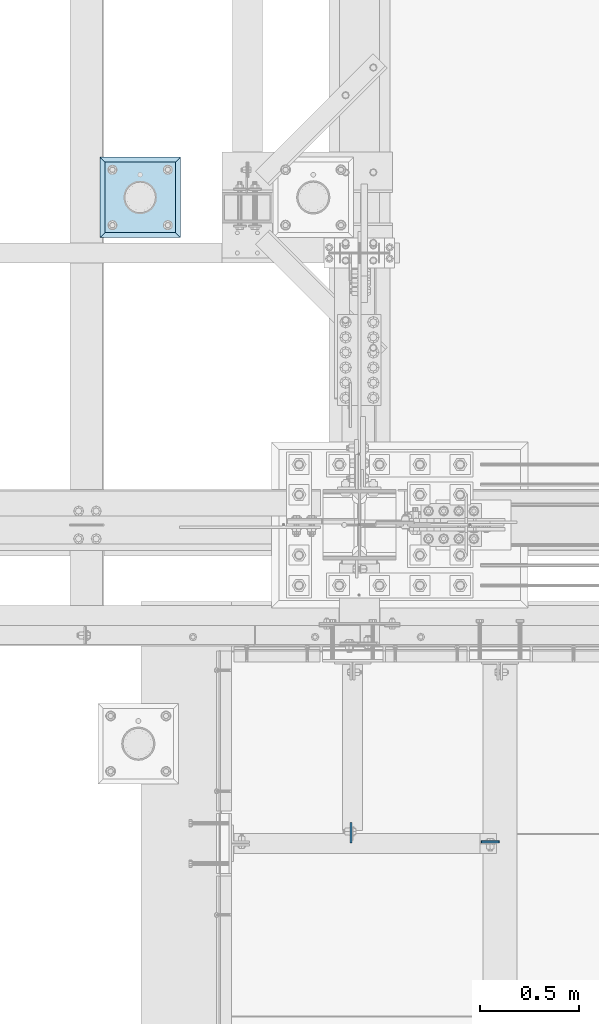
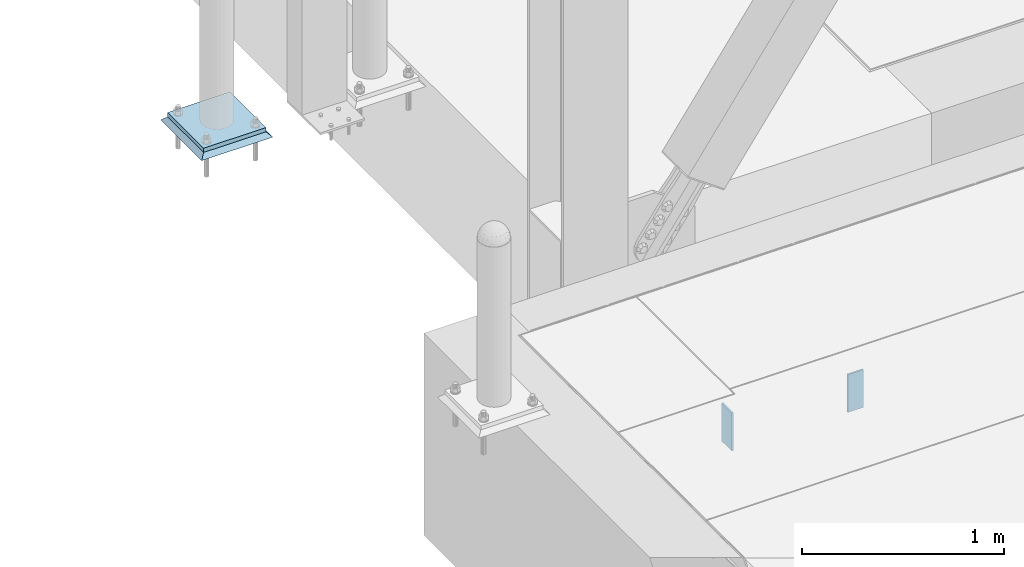
# One storey, part 3028 of 3843: 4 plates, 4 elements without a shape of their own.
"""IFC2X3 building model written with IfcOpenShell, lengths in millimetres."""

from ifc_helpers import new_model, si_unit, frame, origin_with_axes, place, context, subcontext, project, spatial, faceted_brep, material, type_object, element, aggregate, save


model = new_model("IFC2X3")

# Units and contexts
model_context = context("Model", 3, precision=1e-05, world=origin_with_axes())
body_context = subcontext(model_context, "Body", "Model", "MODEL_VIEW")
ifc_project = project(units=[si_unit("LENGTHUNIT", "METRE", prefix="MILLI"), si_unit("AREAUNIT", "SQUARE_METRE"), si_unit("VOLUMEUNIT", "CUBIC_METRE"), si_unit("MASSUNIT", "GRAM", prefix="KILO"), si_unit("TIMEUNIT", "SECOND"), si_unit("PLANEANGLEUNIT", "RADIAN"), si_unit("SOLIDANGLEUNIT", "STERADIAN"), si_unit("THERMODYNAMICTEMPERATUREUNIT", "DEGREE_CELSIUS"), si_unit("LUMINOUSINTENSITYUNIT", "LUMEN")], contexts=[model_context])

# Site, building, storey
site_placement = place(None, origin_with_axes())
site = spatial("IfcSite", under=ifc_project, at=site_placement, CompositionType="ELEMENT")
building_placement = place(site_placement, origin_with_axes())
building = spatial("IfcBuilding", under=site, at=building_placement, Name="Undefined", CompositionType="ELEMENT")
storey_placement = place(building_placement, origin_with_axes())
storey = spatial("IfcBuildingStorey", under=building, at=storey_placement, Name="Undefined", CompositionType="ELEMENT", Elevation=0.0)

# Assembly, plate
assembly_1_placement = place(storey_placement, origin_with_axes())
assembly_1 = element("IfcElementAssembly", 1, at=assembly_1_placement, inside=storey, Name="PIPE_BOLLARD", AssemblyPlace="NOTDEFINED", PredefinedType="RIGID_FRAME")
ifc_material_1 = material(Name="STEEL/A572-50")
plate_type_1 = type_object("IfcPlateType", PredefinedType="NOTDEFINED")
plate_1_placement = place(assembly_1_placement, frame((40778.4782592773, 27089.8153033043, 30518.1), z_axis=(0.0, 1.0, 0.0), x_axis=(1.0, 0.0, 0.0)))
plate_1 = element("IfcPlate", 2, at=plate_1_placement, type_object=plate_type_1, material=ifc_material_1, Name="PLATE", context=body_context, shape_type="Brep", body=[
    faceted_brep([(0.0, -12.6999999999971, 0.0), (0.0, -12.7000000000007, 355.600000000006), (0.0, 12.7000000000007, 355.600000000006), (0.0, 12.6999999999971, 0.0), (355.599999999999, -12.7000000000007, 355.600000000006), (355.599999999999, 12.7000000000007, 355.600000000006), (355.599999999999, -12.7000000000007, 0.0), (355.599999999999, 12.7000000000007, 0.0)], [[[0, 1, 2, 3]], [[1, 4, 5, 2]], [[4, 6, 7, 5]], [[6, 0, 3, 7]], [[5, 7, 3, 2]], [[6, 4, 1, 0]]]),
])
aggregate(assembly_1, [plate_1])

assembly_2_placement = place(storey_placement, origin_with_axes())
assembly_2 = element("IfcElementAssembly", 3, at=assembly_2_placement, inside=storey, Name="GROUT", AssemblyPlace="NOTDEFINED", PredefinedType="REINFORCEMENT_UNIT")
ifc_material_2 = material(Name="CONCRETE/Concrete_Undefined")
plate_type_2 = type_object("IfcPlateType", PredefinedType="NOTDEFINED")
plate_2_placement = place(assembly_2_placement, frame((40753.0782592773, 27064.4153033043, 30492.7), z_axis=(0.0, 1.0, 0.0), x_axis=(1.0, 0.0, 0.0)))
plate_2 = element("IfcPlate", 4, at=plate_2_placement, type_object=plate_type_2, material=ifc_material_2, Name="GROUT", context=body_context, shape_type="Brep", body=[
    faceted_brep([(25.4000000001906, -12.6999999998552, 380.999999999505), (0.0, 12.7000000000007, 406.399999999994), (0.0, 12.6999999999971, 0.0), (25.4000000001906, -12.6999999999898, 25.4000000004453), (380.999999999833, -12.6999999998588, 25.4000000004453), (406.400000000001, 12.7000000000007, 0.0), (406.400000000001, 12.7000000000007, 406.399999999994), (380.999999999833, -12.6999999999898, 380.999999999505)], [[[0, 1, 2, 3]], [[4, 5, 6, 7]], [[4, 7, 0, 3]], [[5, 4, 3, 2]], [[6, 5, 2, 1]], [[7, 6, 1, 0]]]),
])
aggregate(assembly_2, [plate_2])

assembly_3_placement = place(storey_placement, origin_with_axes())
assembly_3 = element("IfcElementAssembly", 5, at=assembly_3_placement, inside=storey, Name="BEAM", AssemblyPlace="NOTDEFINED", PredefinedType="RIGID_FRAME")
plate_type_3 = type_object("IfcPlateType", PredefinedType="NOTDEFINED")
plate_3_placement = place(assembly_3_placement, frame((42766.45625, 24017.2875, 30365.7), z_axis=(-1.0, 0.0, 0.0), x_axis=(0.0, 0.0, -1.0)))
plate_3 = element("IfcPlate", 6, at=plate_3_placement, type_object=plate_type_3, material=ifc_material_1, Name="PLATE", context=body_context, shape_type="Brep", body=[
    faceted_brep([(0.0, -4.76249999999709, 0.0), (0.0, -4.76249999999709, 88.9000015258789), (0.0, 4.76249999999709, 88.9000015258789), (0.0, 4.76249999999709, 0.0), (228.600006102781, -4.7625000004191, 88.9000015257589), (228.600006102781, 4.76249999954598, 88.9000015257443), (228.600006103079, -4.7625000004482, 7.27595761418343e-12), (228.600006103079, 4.76249999954598, -7.27595761418343e-12)], [[[0, 1, 2, 3]], [[1, 4, 5, 2]], [[4, 6, 7, 5]], [[6, 0, 3, 7]], [[5, 7, 3, 2]], [[6, 4, 1, 0]]]),
])
aggregate(assembly_3, [plate_3])

assembly_4_placement = place(storey_placement, origin_with_axes())
assembly_4 = element("IfcElementAssembly", 7, at=assembly_4_placement, inside=storey, Name="BEAM", AssemblyPlace="NOTDEFINED", PredefinedType="RIGID_FRAME")
plate_type_4 = type_object("IfcPlateType", PredefinedType="NOTDEFINED")
plate_4_placement = place(assembly_4_placement, frame((42019.5375, 24012.525, 30365.7), z_axis=(0.0, 1.0, 0.0), x_axis=(0.0, 0.0, -1.0)))
plate_4 = element("IfcPlate", 8, at=plate_4_placement, type_object=plate_type_4, material=ifc_material_1, Name="PLATE", context=body_context, shape_type="Brep", body=[
    faceted_brep([(0.0, -4.76249999999709, 0.0), (0.0, -4.76249999999709, 101.599999999999), (0.0, 4.76249999999709, 101.599999999999), (0.0, 4.76249999999709, 0.0), (228.600006103516, -4.76249999999709, 101.599998474121), (228.600006103516, 4.76249999999709, 101.599998474121), (228.600006103079, -4.7625000004482, 7.27595761418343e-12), (228.600006103079, 4.76249999954598, -7.27595761418343e-12)], [[[0, 1, 2, 3]], [[1, 4, 5, 2]], [[4, 6, 7, 5]], [[6, 0, 3, 7]], [[5, 7, 3, 2]], [[6, 4, 1, 0]]]),
])
aggregate(assembly_4, [plate_4])

save(model, "model.ifc")
